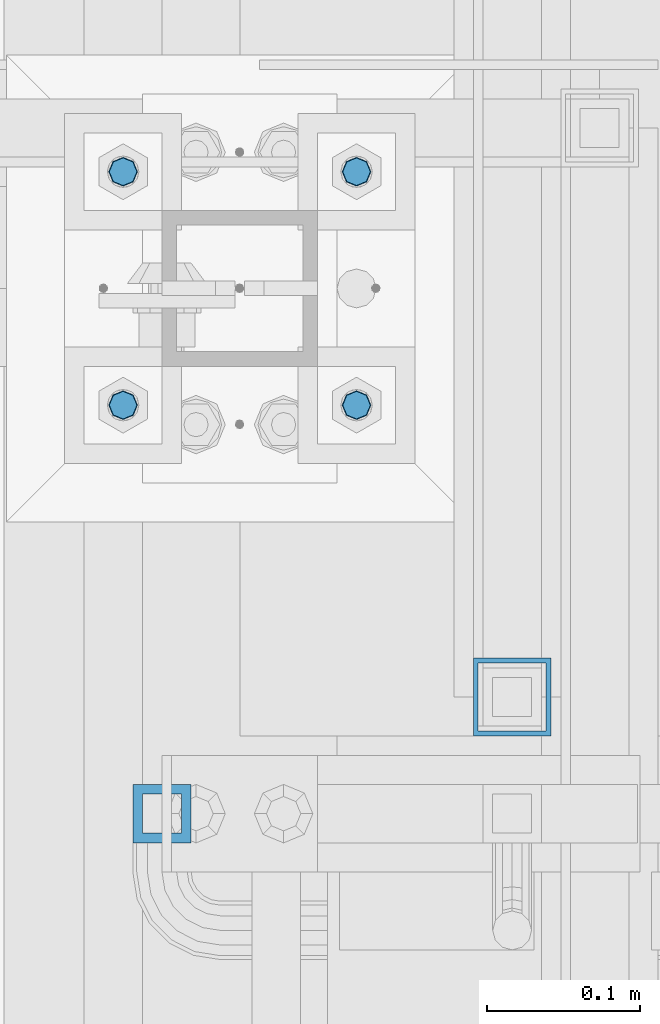
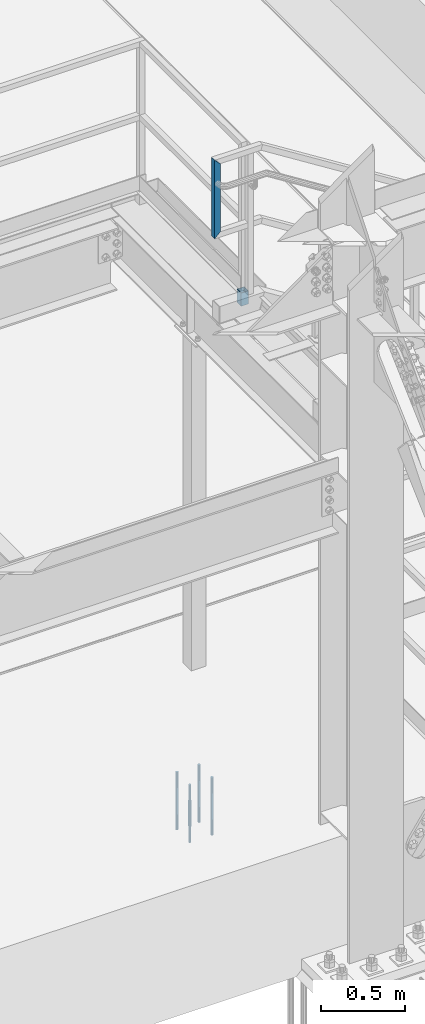
# One storey, part 1494 of 3843: 6 columns, 3 elements without a shape of their own.
"""IFC2X3 building model written with IfcOpenShell, lengths in millimetres."""

from ifc_helpers import new_model, si_unit, frame, origin_with_axes, place, context, subcontext, project, spatial, faceted_brep, material, type_object, element, aggregate, save


model = new_model("IFC2X3")

# Units and contexts
model_context = context("Model", 3, precision=1e-05, world=origin_with_axes())
body_context = subcontext(model_context, "Body", "Model", "MODEL_VIEW")
ifc_project = project(units=[si_unit("LENGTHUNIT", "METRE", prefix="MILLI"), si_unit("AREAUNIT", "SQUARE_METRE"), si_unit("VOLUMEUNIT", "CUBIC_METRE"), si_unit("MASSUNIT", "GRAM", prefix="KILO"), si_unit("TIMEUNIT", "SECOND"), si_unit("PLANEANGLEUNIT", "RADIAN"), si_unit("SOLIDANGLEUNIT", "STERADIAN"), si_unit("THERMODYNAMICTEMPERATUREUNIT", "DEGREE_CELSIUS"), si_unit("LUMINOUSINTENSITYUNIT", "LUMEN")], contexts=[model_context])

# Site, building, storey
site_placement = place(None, origin_with_axes())
site = spatial("IfcSite", under=ifc_project, at=site_placement, CompositionType="ELEMENT")
building_placement = place(site_placement, origin_with_axes())
building = spatial("IfcBuilding", under=site, at=building_placement, Name="Undefined", CompositionType="ELEMENT")
storey_placement = place(building_placement, origin_with_axes())
storey = spatial("IfcBuildingStorey", under=building, at=storey_placement, Name="Undefined", CompositionType="ELEMENT", Elevation=0.0)

# Assembly, column
assembly_1_placement = place(storey_placement, origin_with_axes())
assembly_1 = element("IfcElementAssembly", 1, at=assembly_1_placement, inside=storey, Name="BEAM", AssemblyPlace="NOTDEFINED", PredefinedType="RIGID_FRAME")
ifc_material_1 = material()
column_type_1 = type_object("IfcColumnType", Name="HSS2X2X1/8", PredefinedType="NOTDEFINED")
column_1_placement = place(assembly_1_placement, frame((56108.5999999435, 27330.4000000026, 33204.1499999995), z_axis=(-1.0, 0.0, 0.0), x_axis=(0.0, 0.0, 1.0)))
column_1 = element("IfcColumn", 2, at=column_1_placement, type_object=column_type_1, material=ifc_material_1, Name="POST_SLEEVE", ObjectType="HSS2X2X1/8", context=body_context, shape_type="Brep", body=[
    faceted_brep([(0.0, 22.2249999999985, -22.2249999999985), (0.0, -22.2249999999985, -22.2249999999985), (95.25, -22.2249999999985, -22.2249999999985), (95.25, 22.2249999999985, -22.2249999999985), (0.0, -22.2249999999985, 22.2249999999985), (95.25, -22.2249999999985, 22.2249999999985), (0.0, 22.2249999999985, 22.2249999999985), (95.25, 22.2249999999985, 22.2249999999985), (0.0, 25.4000000000015, -25.4000000000015), (0.0, 25.4000000000015, 25.4000000000015), (95.25, 25.4000000000015, 25.4000000000015), (95.25, 25.4000000000015, -25.4000000000015), (0.0, -25.4000000000015, 25.4000000000015), (95.25, -25.4000000000015, 25.4000000000015), (0.0, -25.4000000000015, -25.4000000000015), (95.25, -25.4000000000015, -25.4000000000015)], [[[0, 1, 2, 3]], [[1, 4, 5, 2]], [[4, 6, 7, 5]], [[6, 0, 3, 7]], [[8, 9, 10, 11]], [[9, 12, 13, 10]], [[12, 14, 15, 13]], [[14, 8, 11, 15]], [[13, 15, 11, 10], [5, 7, 3, 2]], [[14, 12, 9, 8], [6, 4, 1, 0]]]),
])
aggregate(assembly_1, [column_1])

assembly_2_placement = place(storey_placement, origin_with_axes())
assembly_2 = element("IfcElementAssembly", 3, at=assembly_2_placement, inside=storey, Name="RAIL", AssemblyPlace="NOTDEFINED", PredefinedType="RIGID_FRAME")
column_type_2 = type_object("IfcColumnType", Name="HSS1-1/2X1-1/2X1/4", PredefinedType="NOTDEFINED")
column_2_placement = place(assembly_2_placement, frame((55879.9999999771, 27254.20000005, 33832.8000000267), z_axis=(1.0, 0.0, 0.0), x_axis=(0.0, 0.0, 1.0)))
column_2 = element("IfcColumn", 4, at=column_2_placement, type_object=column_type_2, material=ifc_material_1, Name="POST", ObjectType="HSS1-1/2X1-1/2X1/4", context=body_context, shape_type="Brep", body=[
    faceted_brep([(-12.6999993309546, 12.6999993299978, -12.6999993299978), (-12.6999993309546, -12.6999993299978, -12.6999993299978), (546.099999317878, -12.6999993300014, -12.6999993299978), (546.099999317878, 12.6999993300014, -12.6999993299978), (12.6999993290483, -12.6999993299978, 12.6999993299978), (520.700000657882, -12.6999993300014, 12.6999993299978), (12.6999993290483, 12.6999993299978, 12.6999993299978), (520.700000657882, 12.6999993300014, 12.6999993299978), (-19.0499992359546, 19.0499992350015, -19.0499992350015), (19.0499992350015, 19.0499992350015, 19.0499992350015), (514.350000752878, 19.0499992350015, 19.0499992349942), (552.449999222881, 19.0499992350015, -19.0499992349942), (19.0499992350015, -19.0499992350015, 19.0499992350015), (514.350000752878, -19.0499992350015, 19.0499992349942), (-19.0499992359546, -19.0499992350015, -19.0499992350015), (552.449999222881, -19.0499992350015, -19.0499992349942)], [[[0, 1, 2, 3]], [[1, 4, 5, 2]], [[4, 6, 7, 5]], [[6, 0, 3, 7]], [[8, 9, 10, 11]], [[9, 12, 13, 10]], [[12, 14, 15, 13]], [[14, 8, 11, 15]], [[13, 15, 11, 10], [5, 7, 3, 2]], [[14, 12, 9, 8], [6, 4, 1, 0]]]),
])
aggregate(assembly_2, [column_2])

# Assembly, columns
assembly_3_placement = place(storey_placement, origin_with_axes())
assembly_3 = element("IfcElementAssembly", 5, at=assembly_3_placement, inside=storey, Name="TEMPLATE", AssemblyPlace="NOTDEFINED", PredefinedType="RIGID_FRAME")
ifc_material_2 = material(Name="Undefined/F1554-GR.55")
column_type_3 = type_object("IfcColumnType", PredefinedType="NOTDEFINED")
column_3_placement = place(assembly_3_placement, frame((56007.0, 27520.9, 29565.6), z_axis=(1.0, 0.0, 0.0), x_axis=(0.0, 0.0, -1.0)))
column_3 = element("IfcColumn", 6, at=column_3_placement, type_object=column_type_3, material=ifc_material_2, Name="ANCHOR_ROD", context=body_context, shape_type="Brep", body=[
    faceted_brep([(-114.300000000003, -6.36396103068546, 6.36396103067818), (-114.300000000003, 0.0, 9.0), (-114.300000000003, 6.36396103068546, 6.36396103067818), (-114.300000000003, 9.0, 0.0), (-114.300000000003, 6.36396103068546, -6.36396103067818), (-114.300000000003, 0.0, -9.0), (-114.300000000003, -6.36396103068546, -6.36396103067818), (-114.300000000003, -9.0, 0.0), (0.0, 6.36396103068546, -6.36396103067818), (0.0, 0.0, -9.0), (0.0, -6.36396103068546, -6.36396103067818), (0.0, -9.0, 0.0), (0.0, -6.36396103068546, 6.36396103067818), (0.0, 0.0, 9.0), (0.0, 6.36396103068546, 6.36396103067818), (0.0, 9.0, 0.0), (0.0, -6.73519209080405, 6.73519209079677), (-9.87109982941227e-13, 2.91322521661641e-12, 9.52499961853027), (0.0, 6.73519209080405, 6.73519209079677), (0.0, 9.52500000000146, 0.0), (0.0, 6.73519209080405, -6.73519209079677), (2.95075507493764e-12, 2.91322521661641e-12, -9.52499961853027), (0.0, -6.73519209080405, -6.73519209079677), (0.0, -9.52500000000146, 0.0), (190.5, -9.52499999999418, 0.0), (190.5, -6.73519209079677, 6.73519209080405), (190.5, 0.0, 9.52500000000146), (190.5, 6.73519209079677, 6.73519209080405), (190.5, 9.52499999999418, 0.0), (190.5, 6.73519209079677, -6.73519209080405), (190.5, 0.0, -9.52500000000146), (190.5, -6.73519209079677, -6.73519209080405), (190.5, -6.36396103068546, 6.36396103067818), (190.5, 0.0, 9.0), (190.5, 6.36396103068546, 6.36396103067818), (190.5, 9.0, 0.0), (190.5, 6.36396103068546, -6.36396103067818), (190.5, 0.0, -9.0), (190.5, -6.36396103068546, -6.36396103067818), (190.5, -9.0, 0.0), (304.799999999999, 0.0, -9.0), (304.799999999999, 6.36396103068546, -6.36396103067818), (304.799999999999, 9.0, 0.0), (304.799999999999, 6.36396103068546, 6.36396103067818), (304.799999999999, 0.0, 9.0), (304.799999999999, -6.36396103068546, 6.36396103067818), (304.799999999999, -9.0, 0.0), (304.799999999999, -6.36396103068546, -6.36396103067818)], [[[0, 1, 2, 3, 4, 5, 6, 7]], [[5, 4, 8, 9]], [[6, 5, 9, 10]], [[7, 6, 10, 11]], [[0, 7, 11, 12]], [[1, 0, 12, 13]], [[2, 1, 13, 14]], [[3, 2, 14, 15]], [[4, 3, 15, 8]], [[16, 17, 18, 19, 20, 21, 22, 23], [14, 13, 12, 11, 10, 9, 8, 15]], [[16, 23, 24, 25]], [[17, 16, 25, 26]], [[18, 17, 26, 27]], [[19, 18, 27, 28]], [[20, 19, 28, 29]], [[21, 20, 29, 30]], [[22, 21, 30, 31]], [[23, 22, 31, 24]], [[30, 29, 28, 27, 26, 25, 24, 31], [32, 33, 34, 35, 36, 37, 38, 39]], [[40, 41, 42, 43, 44, 45, 46, 47]], [[45, 44, 33, 32]], [[46, 45, 32, 39]], [[47, 46, 39, 38]], [[40, 47, 38, 37]], [[41, 40, 37, 36]], [[42, 41, 36, 35]], [[43, 42, 35, 34]], [[44, 43, 34, 33]]]),
])
column_4_placement = place(assembly_3_placement, frame((56007.0, 27673.3, 29565.6), z_axis=(-1.0, 0.0, 0.0), x_axis=(0.0, 0.0, -1.0)))
column_4 = element("IfcColumn", 7, at=column_4_placement, type_object=column_type_3, material=ifc_material_2, Name="ANCHOR_ROD", context=body_context, shape_type="Brep", body=[
    faceted_brep([(-114.300000000003, -6.36396103068546, 6.36396103067818), (-114.300000000003, 0.0, 9.0), (-114.300000000003, 6.36396103068546, 6.36396103067818), (-114.300000000003, 9.0, 0.0), (-114.300000000003, 6.36396103068546, -6.36396103067818), (-114.300000000003, 0.0, -9.0), (-114.300000000003, -6.36396103068546, -6.36396103067818), (-114.300000000003, -9.0, 0.0), (0.0, 6.36396103068546, -6.36396103067818), (0.0, 0.0, -9.0), (0.0, -6.36396103068546, -6.36396103067818), (0.0, -9.0, 0.0), (0.0, -6.36396103068546, 6.36396103067818), (0.0, 0.0, 9.0), (0.0, 6.36396103068546, 6.36396103067818), (0.0, 9.0, 0.0), (0.0, -6.73519209080405, 6.73519209079677), (-9.87109982941227e-13, 2.91322521661641e-12, 9.52499961853027), (0.0, 6.73519209080405, 6.73519209079677), (0.0, 9.52500000000146, 0.0), (0.0, 6.73519209080405, -6.73519209079677), (2.95075507493764e-12, 2.91322521661641e-12, -9.52499961853027), (0.0, -6.73519209080405, -6.73519209079677), (0.0, -9.52500000000146, 0.0), (190.5, -9.52499999999418, 0.0), (190.5, -6.73519209079677, 6.73519209080405), (190.5, 0.0, 9.52500000000146), (190.5, 6.73519209079677, 6.73519209080405), (190.5, 9.52499999999418, 0.0), (190.5, 6.73519209079677, -6.73519209080405), (190.5, 0.0, -9.52500000000146), (190.5, -6.73519209079677, -6.73519209080405), (190.5, -6.36396103068546, 6.36396103067818), (190.5, 0.0, 9.0), (190.5, 6.36396103068546, 6.36396103067818), (190.5, 9.0, 0.0), (190.5, 6.36396103068546, -6.36396103067818), (190.5, 0.0, -9.0), (190.5, -6.36396103068546, -6.36396103067818), (190.5, -9.0, 0.0), (304.799999999999, 0.0, -9.0), (304.799999999999, 6.36396103068546, -6.36396103067818), (304.799999999999, 9.0, 0.0), (304.799999999999, 6.36396103068546, 6.36396103067818), (304.799999999999, 0.0, 9.0), (304.799999999999, -6.36396103068546, 6.36396103067818), (304.799999999999, -9.0, 0.0), (304.799999999999, -6.36396103068546, -6.36396103067818)], [[[0, 1, 2, 3, 4, 5, 6, 7]], [[5, 4, 8, 9]], [[6, 5, 9, 10]], [[7, 6, 10, 11]], [[0, 7, 11, 12]], [[1, 0, 12, 13]], [[2, 1, 13, 14]], [[3, 2, 14, 15]], [[4, 3, 15, 8]], [[16, 17, 18, 19, 20, 21, 22, 23], [14, 13, 12, 11, 10, 9, 8, 15]], [[16, 23, 24, 25]], [[17, 16, 25, 26]], [[18, 17, 26, 27]], [[19, 18, 27, 28]], [[20, 19, 28, 29]], [[21, 20, 29, 30]], [[22, 21, 30, 31]], [[23, 22, 31, 24]], [[30, 29, 28, 27, 26, 25, 24, 31], [32, 33, 34, 35, 36, 37, 38, 39]], [[40, 41, 42, 43, 44, 45, 46, 47]], [[45, 44, 33, 32]], [[46, 45, 32, 39]], [[47, 46, 39, 38]], [[40, 47, 38, 37]], [[41, 40, 37, 36]], [[42, 41, 36, 35]], [[43, 42, 35, 34]], [[44, 43, 34, 33]]]),
])
column_5_placement = place(assembly_3_placement, frame((55854.6, 27520.9, 29565.6), z_axis=(1.0, 0.0, 0.0), x_axis=(0.0, 0.0, -1.0)))
column_5 = element("IfcColumn", 8, at=column_5_placement, type_object=column_type_3, material=ifc_material_2, Name="ANCHOR_ROD", context=body_context, shape_type="Brep", body=[
    faceted_brep([(-114.300000000003, -6.36396103068546, 6.36396103067818), (-114.300000000003, 0.0, 9.0), (-114.300000000003, 6.36396103068546, 6.36396103067818), (-114.300000000003, 9.0, 0.0), (-114.300000000003, 6.36396103068546, -6.36396103067818), (-114.300000000003, 0.0, -9.0), (-114.300000000003, -6.36396103068546, -6.36396103067818), (-114.300000000003, -9.0, 0.0), (0.0, 6.36396103068546, -6.36396103067818), (0.0, 0.0, -9.0), (0.0, -6.36396103068546, -6.36396103067818), (0.0, -9.0, 0.0), (0.0, -6.36396103068546, 6.36396103067818), (0.0, 0.0, 9.0), (0.0, 6.36396103068546, 6.36396103067818), (0.0, 9.0, 0.0), (0.0, -6.73519209080405, 6.73519209079677), (-9.87109982941227e-13, 2.91322521661641e-12, 9.52499961853027), (0.0, 6.73519209080405, 6.73519209079677), (0.0, 9.52500000000146, 0.0), (0.0, 6.73519209080405, -6.73519209079677), (2.95075507493764e-12, 2.91322521661641e-12, -9.52499961853027), (0.0, -6.73519209080405, -6.73519209079677), (0.0, -9.52500000000146, 0.0), (190.5, -9.52499999999418, 0.0), (190.5, -6.73519209079677, 6.73519209080405), (190.5, 0.0, 9.52500000000146), (190.5, 6.73519209079677, 6.73519209080405), (190.5, 9.52499999999418, 0.0), (190.5, 6.73519209079677, -6.73519209080405), (190.5, 0.0, -9.52500000000146), (190.5, -6.73519209079677, -6.73519209080405), (190.5, -6.36396103068546, 6.36396103067818), (190.5, 0.0, 9.0), (190.5, 6.36396103068546, 6.36396103067818), (190.5, 9.0, 0.0), (190.5, 6.36396103068546, -6.36396103067818), (190.5, 0.0, -9.0), (190.5, -6.36396103068546, -6.36396103067818), (190.5, -9.0, 0.0), (304.799999999999, 0.0, -9.0), (304.799999999999, 6.36396103068546, -6.36396103067818), (304.799999999999, 9.0, 0.0), (304.799999999999, 6.36396103068546, 6.36396103067818), (304.799999999999, 0.0, 9.0), (304.799999999999, -6.36396103068546, 6.36396103067818), (304.799999999999, -9.0, 0.0), (304.799999999999, -6.36396103068546, -6.36396103067818)], [[[0, 1, 2, 3, 4, 5, 6, 7]], [[5, 4, 8, 9]], [[6, 5, 9, 10]], [[7, 6, 10, 11]], [[0, 7, 11, 12]], [[1, 0, 12, 13]], [[2, 1, 13, 14]], [[3, 2, 14, 15]], [[4, 3, 15, 8]], [[16, 17, 18, 19, 20, 21, 22, 23], [14, 13, 12, 11, 10, 9, 8, 15]], [[16, 23, 24, 25]], [[17, 16, 25, 26]], [[18, 17, 26, 27]], [[19, 18, 27, 28]], [[20, 19, 28, 29]], [[21, 20, 29, 30]], [[22, 21, 30, 31]], [[23, 22, 31, 24]], [[30, 29, 28, 27, 26, 25, 24, 31], [32, 33, 34, 35, 36, 37, 38, 39]], [[40, 41, 42, 43, 44, 45, 46, 47]], [[45, 44, 33, 32]], [[46, 45, 32, 39]], [[47, 46, 39, 38]], [[40, 47, 38, 37]], [[41, 40, 37, 36]], [[42, 41, 36, 35]], [[43, 42, 35, 34]], [[44, 43, 34, 33]]]),
])
column_6_placement = place(assembly_3_placement, frame((55854.6, 27673.3, 29565.6), z_axis=(-1.0, 0.0, 0.0), x_axis=(0.0, 0.0, -1.0)))
column_6 = element("IfcColumn", 9, at=column_6_placement, type_object=column_type_3, material=ifc_material_2, Name="ANCHOR_ROD", context=body_context, shape_type="Brep", body=[
    faceted_brep([(-114.300000000003, -6.36396103068546, 6.36396103067818), (-114.300000000003, 0.0, 9.0), (-114.300000000003, 6.36396103068546, 6.36396103067818), (-114.300000000003, 9.0, 0.0), (-114.300000000003, 6.36396103068546, -6.36396103067818), (-114.300000000003, 0.0, -9.0), (-114.300000000003, -6.36396103068546, -6.36396103067818), (-114.300000000003, -9.0, 0.0), (0.0, 6.36396103068546, -6.36396103067818), (0.0, 0.0, -9.0), (0.0, -6.36396103068546, -6.36396103067818), (0.0, -9.0, 0.0), (0.0, -6.36396103068546, 6.36396103067818), (0.0, 0.0, 9.0), (0.0, 6.36396103068546, 6.36396103067818), (0.0, 9.0, 0.0), (0.0, -6.73519209080405, 6.73519209079677), (-9.87109982941227e-13, 2.91322521661641e-12, 9.52499961853027), (0.0, 6.73519209080405, 6.73519209079677), (0.0, 9.52500000000146, 0.0), (0.0, 6.73519209080405, -6.73519209079677), (2.95075507493764e-12, 2.91322521661641e-12, -9.52499961853027), (0.0, -6.73519209080405, -6.73519209079677), (0.0, -9.52500000000146, 0.0), (190.5, -9.52499999999418, 0.0), (190.5, -6.73519209079677, 6.73519209080405), (190.5, 0.0, 9.52500000000146), (190.5, 6.73519209079677, 6.73519209080405), (190.5, 9.52499999999418, 0.0), (190.5, 6.73519209079677, -6.73519209080405), (190.5, 0.0, -9.52500000000146), (190.5, -6.73519209079677, -6.73519209080405), (190.5, -6.36396103068546, 6.36396103067818), (190.5, 0.0, 9.0), (190.5, 6.36396103068546, 6.36396103067818), (190.5, 9.0, 0.0), (190.5, 6.36396103068546, -6.36396103067818), (190.5, 0.0, -9.0), (190.5, -6.36396103068546, -6.36396103067818), (190.5, -9.0, 0.0), (304.799999999999, 0.0, -9.0), (304.799999999999, 6.36396103068546, -6.36396103067818), (304.799999999999, 9.0, 0.0), (304.799999999999, 6.36396103068546, 6.36396103067818), (304.799999999999, 0.0, 9.0), (304.799999999999, -6.36396103068546, 6.36396103067818), (304.799999999999, -9.0, 0.0), (304.799999999999, -6.36396103068546, -6.36396103067818)], [[[0, 1, 2, 3, 4, 5, 6, 7]], [[5, 4, 8, 9]], [[6, 5, 9, 10]], [[7, 6, 10, 11]], [[0, 7, 11, 12]], [[1, 0, 12, 13]], [[2, 1, 13, 14]], [[3, 2, 14, 15]], [[4, 3, 15, 8]], [[16, 17, 18, 19, 20, 21, 22, 23], [14, 13, 12, 11, 10, 9, 8, 15]], [[16, 23, 24, 25]], [[17, 16, 25, 26]], [[18, 17, 26, 27]], [[19, 18, 27, 28]], [[20, 19, 28, 29]], [[21, 20, 29, 30]], [[22, 21, 30, 31]], [[23, 22, 31, 24]], [[30, 29, 28, 27, 26, 25, 24, 31], [32, 33, 34, 35, 36, 37, 38, 39]], [[40, 41, 42, 43, 44, 45, 46, 47]], [[45, 44, 33, 32]], [[46, 45, 32, 39]], [[47, 46, 39, 38]], [[40, 47, 38, 37]], [[41, 40, 37, 36]], [[42, 41, 36, 35]], [[43, 42, 35, 34]], [[44, 43, 34, 33]]]),
])
aggregate(assembly_3, [column_3, column_4, column_5, column_6])

save(model, "model.ifc")
